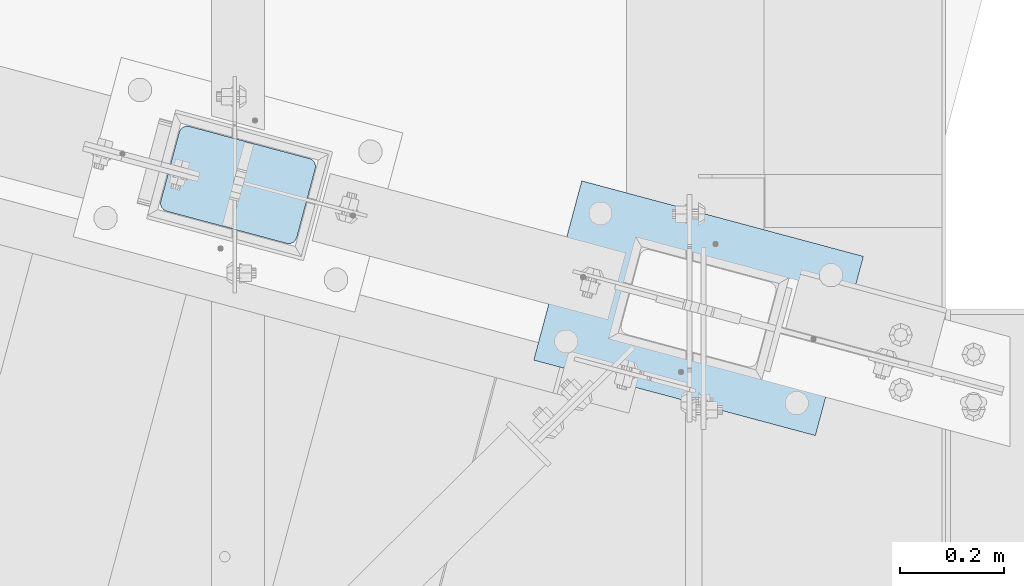
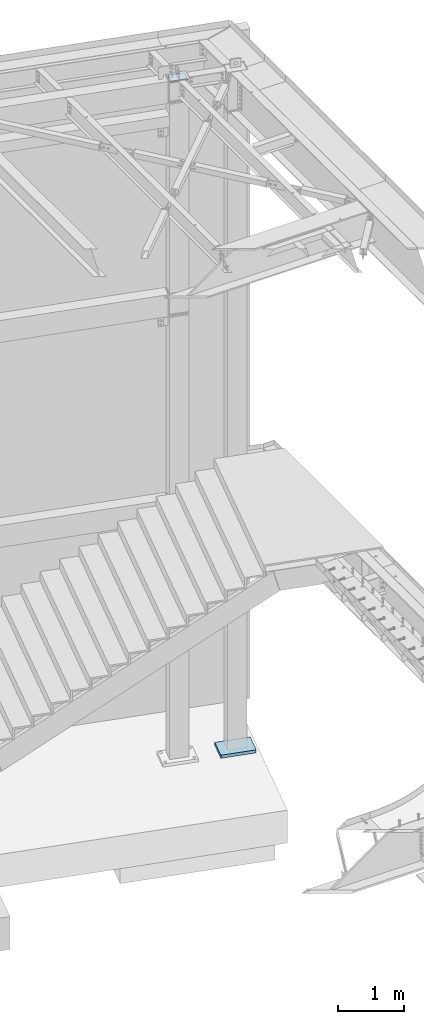
# One storey, part 1701 of 1763: 2 plates, 2 elements without a shape of their own.
"""IFC2X3 building model written with IfcOpenShell, lengths in millimetres."""

from ifc_helpers import new_model, si_unit, frame, origin_with_axes, place, context, subcontext, project, spatial, faceted_brep, material, type_object, element, aggregate, save


model = new_model("IFC2X3")

# Units and contexts
model_context = context("Model", 3, precision=1e-05, world=origin_with_axes())
body_context = subcontext(model_context, "Body", "Model", "MODEL_VIEW")
ifc_project = project(units=[si_unit("LENGTHUNIT", "METRE", prefix="MILLI"), si_unit("AREAUNIT", "SQUARE_METRE"), si_unit("VOLUMEUNIT", "CUBIC_METRE"), si_unit("MASSUNIT", "GRAM", prefix="KILO"), si_unit("TIMEUNIT", "SECOND"), si_unit("PLANEANGLEUNIT", "RADIAN"), si_unit("SOLIDANGLEUNIT", "STERADIAN"), si_unit("THERMODYNAMICTEMPERATUREUNIT", "DEGREE_CELSIUS"), si_unit("LUMINOUSINTENSITYUNIT", "LUMEN")], contexts=[model_context])

# Site, building, storey
site_placement = place(None, origin_with_axes())
site = spatial("IfcSite", under=ifc_project, at=site_placement, CompositionType="ELEMENT")
building_placement = place(site_placement, origin_with_axes())
building = spatial("IfcBuilding", under=site, at=building_placement, Name="Undefined", CompositionType="ELEMENT")
storey_placement = place(building_placement, origin_with_axes())
storey = spatial("IfcBuildingStorey", under=building, at=storey_placement, Name="Undefined", CompositionType="ELEMENT", Elevation=0.0)

# Assembly, plate
assembly_1_placement = place(storey_placement, origin_with_axes())
assembly_1 = element("IfcElementAssembly", 1, at=assembly_1_placement, inside=storey, Name="COLUMN", AssemblyPlace="NOTDEFINED", PredefinedType="RIGID_FRAME")
ifc_material_1 = material(Name="STEEL/A36")
plate_type_1 = type_object("IfcPlateType", PredefinedType="NOTDEFINED")
plate_1_placement = place(assembly_1_placement, frame((-22654.8922023227, 62208.6264264629, 12420.6), z_axis=(0.965913267114843, -0.258865912030785, 0.0), x_axis=(-0.258865912030778, -0.965913267114844, 3.00823476209188e-08)))
plate_1 = element("IfcPlate", 2, at=plate_1_placement, type_object=plate_type_1, material=ifc_material_1, Name="PLATE", context=body_context, shape_type="Brep", body=[
    faceted_brep([(-2.18278728425503e-11, -12.7000000000007, 15.875), (-1.67347025126219e-10, -12.7000000000007, 253.999999999985), (-1.67347025126219e-10, 12.7000000000007, 253.999999999985), (-2.18278728425503e-11, 12.7000000000007, 15.875), (1.20841242121242, -12.7000000000007, 260.075099488779), (1.20841242121242, 12.7000000000007, 260.075099488779), (4.649679848495, -12.7000000000007, 265.225320151323), (4.649679848495, 12.7000000000007, 265.225320151323), (9.79990051103232, -12.7000000000007, 268.666587578606), (9.79990051103232, 12.7000000000007, 268.666587578606), (15.8749999998181, -12.7000000000007, 269.874999999993), (15.8749999998181, 12.7000000000007, 269.874999999993), (152.400009155084, -12.7000000000007, 269.875000000073), (152.400009155084, 12.7000000000007, 269.875000000073), (158.475108643877, -12.7000000000007, 268.6665875787), (158.475108643877, 12.7000000000007, 268.6665875787), (163.625329306422, -12.7000000000007, 265.225320151425), (163.625329306422, 12.7000000000007, 265.225320151425), (167.066596733705, -12.7000000000007, 260.07509948888), (167.066596733705, 12.7000000000007, 260.07509948888), (168.275009155092, -12.7000000000007, 254.000000000087), (168.275009155092, 12.7000000000007, 254.000000000087), (168.275009155237, -12.7000000000007, 15.8750000001019), (168.275009155237, 12.7000000000007, 15.8750000001019), (167.066596733865, -12.7000000000007, 9.79990051130881), (167.066596733865, 12.7000000000007, 9.79990051130881), (163.625329306582, -12.7000000000007, 4.64967984876421), (163.625329306582, 12.7000000000007, 4.64967984876421), (158.475108644045, -12.7000000000007, 1.20841242148163), (158.475108644045, 12.7000000000007, 1.20841242148163), (152.400000000001, -12.6999998092651, 0.0), (152.400000000001, 12.6999998092651, 0.0), (15.8749999999854, -12.7000000000007, 0.0), (15.8749999999854, 12.7000000000007, 0.0), (9.79990051119239, -12.7000000000007, 1.20841242137976), (9.79990051119239, 12.7000000000007, 1.20841242137976), (4.64967984864779, -12.7000000000007, 4.64967984866234), (4.64967984864779, 12.7000000000007, 4.64967984866234), (1.20841242136521, -12.7000000000007, 9.79990051119967), (1.20841242136521, 12.7000000000007, 9.79990051119967)], [[[0, 1, 2, 3]], [[1, 4, 5, 2]], [[4, 6, 7, 5]], [[6, 8, 9, 7]], [[8, 10, 11, 9]], [[10, 12, 13, 11]], [[12, 14, 15, 13]], [[14, 16, 17, 15]], [[16, 18, 19, 17]], [[18, 20, 21, 19]], [[20, 22, 23, 21]], [[22, 24, 25, 23]], [[24, 26, 27, 25]], [[26, 28, 29, 27]], [[28, 30, 31, 29]], [[30, 32, 33, 31]], [[32, 34, 35, 33]], [[34, 36, 37, 35]], [[36, 38, 39, 37]], [[38, 0, 3, 39]], [[5, 7, 9, 11, 13, 15, 17, 19, 21, 23, 25, 27, 29, 31, 33, 35, 37, 39, 3, 2]], [[38, 36, 34, 32, 30, 28, 26, 24, 22, 20, 18, 16, 14, 12, 10, 8, 6, 4, 1, 0]]]),
])
aggregate(assembly_1, [plate_1])

assembly_2_placement = place(storey_placement, origin_with_axes())
assembly_2 = element("IfcElementAssembly", 3, at=assembly_2_placement, inside=storey, Name="COLUMN", AssemblyPlace="NOTDEFINED", PredefinedType="RIGID_FRAME")
ifc_material_2 = material(Name="STEEL/A572-GR.50")
plate_type_2 = type_object("IfcPlateType", PredefinedType="NOTDEFINED")
plate_2_placement = place(assembly_2_placement, frame((-21979.5821434393, 61756.5978212067, -200.025), z_axis=(0.25886591203079, 0.965913267114842, 0.0), x_axis=(0.965913267114843, -0.258865912030785, 0.0)))
plate_2 = element("IfcPlate", 4, at=plate_2_placement, type_object=plate_type_2, material=ifc_material_2, Name="PLATE", context=body_context, shape_type="Brep", body=[
    faceted_brep([(0.0, -28.575, 0.0), (-2.18278728425503e-10, -28.575, 355.600006103494), (-2.18278728425503e-10, 28.575, 355.600006103494), (0.0, 28.575, 0.0), (558.799987792721, -28.575, 355.60000610385), (558.799987792721, 28.575, 355.60000610385), (558.79998779294, -28.575, 3.49245965480804e-10), (558.79998779294, 28.575, 3.49245965480804e-10)], [[[0, 1, 2, 3]], [[1, 4, 5, 2]], [[4, 6, 7, 5]], [[6, 0, 3, 7]], [[5, 7, 3, 2]], [[6, 4, 1, 0]]]),
])
aggregate(assembly_2, [plate_2])

save(model, "model.ifc")
